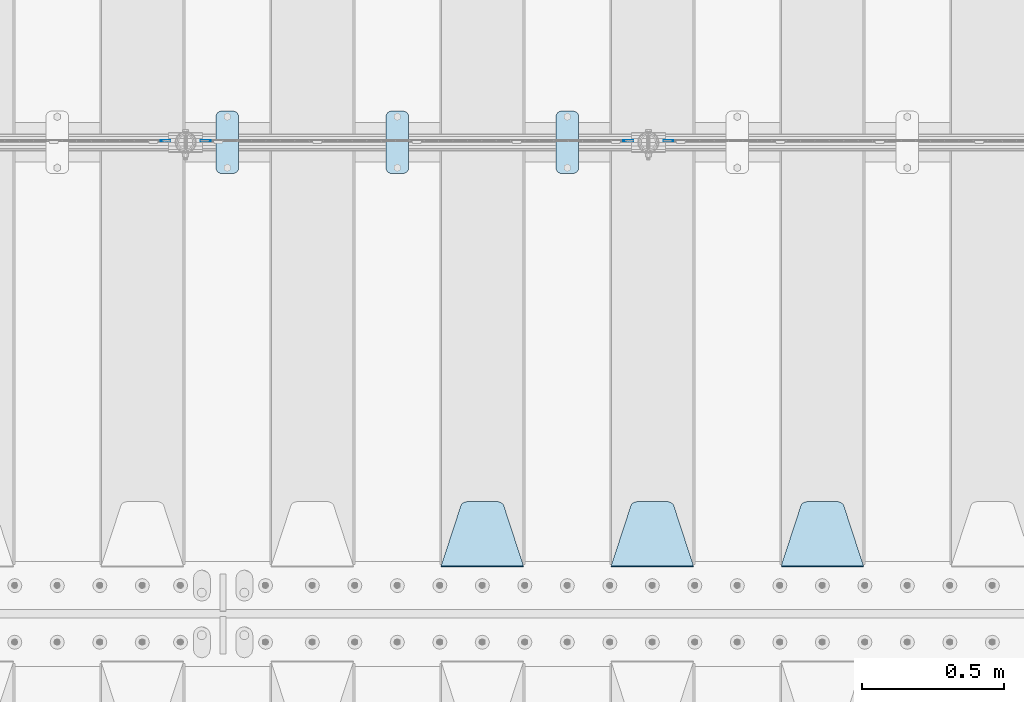
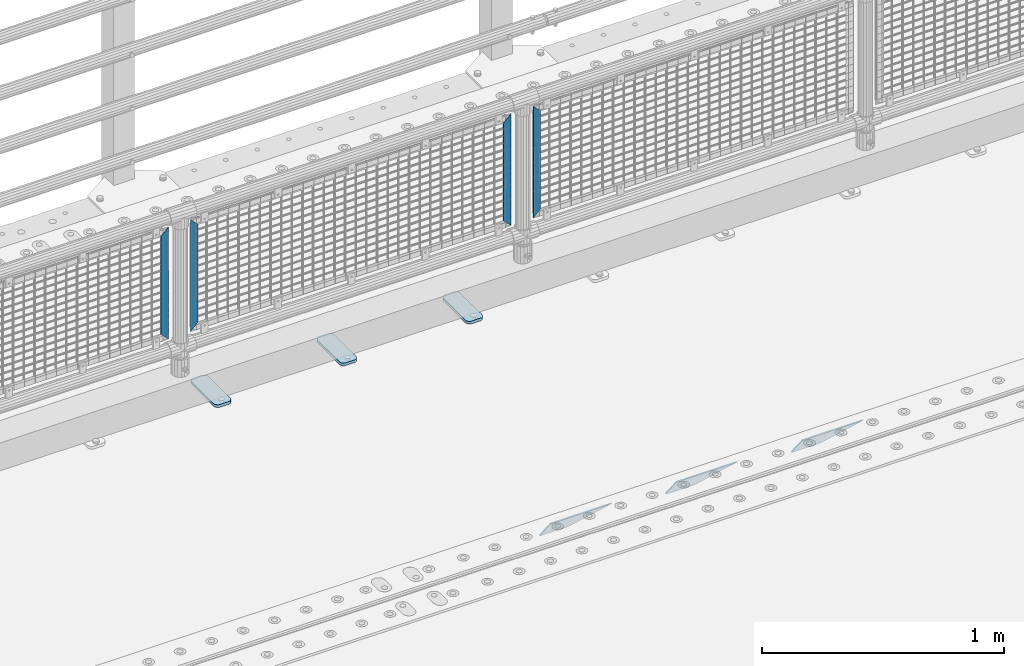
# One storey, part 210 of 242: 10 plates.
"""IFC2X3 building model written with IfcOpenShell, lengths in millimetres."""

from ifc_helpers import new_model, si_unit, frame, origin_with_axes, place, context, subcontext, project, spatial, faceted_brep, material, type_object, element, save


model = new_model("IFC2X3")

# Units and contexts
model_context = context("Model", 3, precision=1e-05, world=origin_with_axes())
body_context = subcontext(model_context, "Body", "Model", "MODEL_VIEW")
ifc_project = project(units=[si_unit("LENGTHUNIT", "METRE", prefix="MILLI"), si_unit("AREAUNIT", "SQUARE_METRE"), si_unit("VOLUMEUNIT", "CUBIC_METRE"), si_unit("MASSUNIT", "GRAM", prefix="KILO"), si_unit("TIMEUNIT", "SECOND"), si_unit("PLANEANGLEUNIT", "RADIAN"), si_unit("SOLIDANGLEUNIT", "STERADIAN"), si_unit("THERMODYNAMICTEMPERATUREUNIT", "DEGREE_CELSIUS"), si_unit("LUMINOUSINTENSITYUNIT", "LUMEN")], contexts=[model_context])

# Site, building, storey
site_placement = place(None, origin_with_axes())
site = spatial("IfcSite", under=ifc_project, at=site_placement, CompositionType="ELEMENT")
building_placement = place(site_placement, origin_with_axes())
building = spatial("IfcBuilding", under=site, at=building_placement, Name="Standard", CompositionType="ELEMENT")
storey_placement = place(building_placement, origin_with_axes())
storey = spatial("IfcBuildingStorey", under=building, at=storey_placement, Name="Undefined", CompositionType="ELEMENT", Elevation=0.0)

# Plates
ifc_material_1 = material(Name="Misc_Undefined")
plate_type_1 = type_object("IfcPlateType", PredefinedType="NOTDEFINED")
for number, where, z_axis, x_axis in (
    (1, (-33575.490286459, -19329.5, 879.519963133601), (-0.707008801899319, 0.0, -0.707204746899291), (-0.707204746899296, 0.0, 0.707008801899313)),
    (2, (-35208.490286459, -19329.5, 879.519963133601), (-0.707008801899319, 0.0, -0.707204746899291), (-0.707204746899296, 0.0, 0.707008801899313)),
):
    element("IfcPlate", number, at=place(storey_placement, frame(where, z_axis=z_axis, x_axis=x_axis)), inside=storey, type_object=plate_type_1, material=ifc_material_1, context=body_context, shape_type="Brep", body=[
        faceted_brep([(0.0, -1.50000000000364, 0.0), (-348.552185058597, -1.5, 348.655029296875), (-348.552185058597, 1.5, 348.655029296875), (-3.63797880709171e-12, 1.49999999999636, 0.0), (-348.544891357426, -1.5, 398.152496337891), (-348.544891357426, 1.5, 398.152496337891), (49.5043945312464, -1.5, 8.00355337560177e-11), (49.5043945312464, 1.5, 8.00355337560177e-11)], [[[0, 1, 2, 3]], [[1, 4, 5, 2]], [[4, 6, 7, 5]], [[6, 0, 3, 7]], [[5, 7, 3, 2]], [[6, 4, 1, 0]]]),
    ])
for number, where, z_axis, x_axis in (
    (3, (-33752.5003125164, -19329.5, 879.52), (0.707103624179499, 0.0, -0.707109938179501), (0.707109938179508, 0.0, 0.707103624179492)),
    (4, (-35385.5003125164, -19329.5, 879.52), (0.707103624179499, 0.0, -0.707109938179501), (0.707109938179508, 0.0, 0.707103624179492)),
):
    element("IfcPlate", number, at=place(storey_placement, frame(where, z_axis=z_axis, x_axis=x_axis)), inside=storey, type_object=plate_type_1, material=ifc_material_1, context=body_context, shape_type="Brep", body=[
        faceted_brep([(0.0, -1.50000000000364, 0.0), (-348.605163574222, -1.5, 348.602081298832), (-348.605163574222, 1.5, 348.602081298832), (-3.63797880709171e-12, 1.49999999999636, 0.0), (-348.605163574222, -1.5, 398.099334716801), (-348.605163574222, 1.5, 398.099334716801), (49.4976959228534, -1.5, -3.63797880709171e-12), (49.4976959228534, 1.5, -3.63797880709171e-12)], [[[0, 1, 2, 3]], [[1, 4, 5, 2]], [[4, 6, 7, 5]], [[6, 0, 3, 7]], [[5, 7, 3, 2]], [[6, 4, 1, 0]]]),
    ])
ifc_material_2 = material(Name="STEEL/S355J2")
plate_type_2 = type_object("IfcPlateType", PredefinedType="NOTDEFINED")
plate_1_placement = place(storey_placement, frame((-33990.0, -19225.5, 21.0199999999977), z_axis=(1.0, 0.0, 0.0), x_axis=(0.0, -1.0, 0.0)))
element("IfcPlate", 5, at=plate_1_placement, inside=storey, type_object=plate_type_2, material=ifc_material_2, context=body_context, shape_type="Brep", body=[
    faceted_brep([(0.0, -7.0, 20.0), (0.0, -7.0, 60.0), (0.0, 7.0, 60.0), (0.0, 7.0, 20.0), (0.384294391937146, -7.0, 63.9018064403208), (0.384294391937146, 7.0, 63.9018064403208), (1.52240934977453, -7.0, 67.6536686473009), (1.52240934977453, 7.0, 67.6536686473009), (3.37060775395003, -7.0, 71.1114046603907), (3.37060775395003, 7.0, 71.1114046603907), (5.8578643762703, -7.0, 74.1421356237297), (5.8578643762703, 7.0, 74.1421356237297), (8.88859533960931, -7.0, 76.62939224605), (8.88859533960931, 7.0, 76.62939224605), (12.3463313526991, -7.0, 78.4775906502255), (12.3463313526991, 7.0, 78.4775906502255), (16.0981935596792, -7.0, 79.6157056080629), (16.0981935596792, 7.0, 79.6157056080629), (20.0, -7.0, 80.0), (20.0, 7.0, 80.0), (200.0, -7.0, 80.0), (200.0, 7.0, 80.0), (203.901806440321, -7.0, 79.6157056080629), (203.901806440321, 7.0, 79.6157056080629), (207.653668647301, -7.0, 78.4775906502255), (207.653668647301, 7.0, 78.4775906502255), (211.111404660391, -7.0, 76.62939224605), (211.111404660391, 7.0, 76.62939224605), (214.14213562373, -7.0, 74.1421356237297), (214.14213562373, 7.0, 74.1421356237297), (216.62939224605, -7.0, 71.1114046603907), (216.62939224605, 7.0, 71.1114046603907), (218.477590650225, -7.0, 67.6536686473009), (218.477590650225, 7.0, 67.6536686473009), (219.615705608063, -7.0, 63.9018064403208), (219.615705608063, 7.0, 63.9018064403208), (220.0, -7.0, 60.0), (220.0, 7.0, 60.0), (220.0, -7.0, 20.0), (220.0, 7.0, 20.0), (219.615705608063, -7.0, 16.0981935596792), (219.615705608063, 7.0, 16.0981935596792), (218.477590650225, -7.0, 12.3463313526991), (218.477590650225, 7.0, 12.3463313526991), (216.62939224605, -7.0, 8.88859533960931), (216.62939224605, 7.0, 8.88859533960931), (214.14213562373, -7.0, 5.8578643762703), (214.14213562373, 7.0, 5.8578643762703), (211.111404660391, -7.0, 3.37060775395003), (211.111404660391, 7.0, 3.37060775395003), (207.653668647301, -7.0, 1.52240934977453), (207.653668647301, 7.0, 1.52240934977453), (203.901806440321, -7.0, 0.384294391937146), (203.901806440321, 7.0, 0.384294391937146), (200.0, -7.0, 0.0), (200.0, 7.0, 0.0), (20.0, -7.0, 0.0), (20.0, 7.0, 0.0), (16.0981935596792, -7.0, 0.384294391937146), (16.0981935596792, 7.0, 0.384294391937146), (12.3463313526991, -7.0, 1.52240934977453), (12.3463313526991, 7.0, 1.52240934977453), (8.88859533960931, -7.0, 3.37060775395003), (8.88859533960931, 7.0, 3.37060775395003), (5.8578643762703, -7.0, 5.8578643762703), (5.8578643762703, 7.0, 5.8578643762703), (3.37060775395003, -7.0, 8.88859533960931), (3.37060775395003, 7.0, 8.88859533960931), (1.52240934977453, -7.0, 12.3463313526991), (1.52240934977453, 7.0, 12.3463313526991), (0.384294391937146, -7.0, 16.0981935596792), (0.384294391937146, 7.0, 16.0981935596792)], [[[0, 1, 2, 3]], [[1, 4, 5, 2]], [[4, 6, 7, 5]], [[6, 8, 9, 7]], [[8, 10, 11, 9]], [[10, 12, 13, 11]], [[12, 14, 15, 13]], [[14, 16, 17, 15]], [[16, 18, 19, 17]], [[18, 20, 21, 19]], [[20, 22, 23, 21]], [[22, 24, 25, 23]], [[24, 26, 27, 25]], [[26, 28, 29, 27]], [[28, 30, 31, 29]], [[30, 32, 33, 31]], [[32, 34, 35, 33]], [[34, 36, 37, 35]], [[36, 38, 39, 37]], [[38, 40, 41, 39]], [[40, 42, 43, 41]], [[42, 44, 45, 43]], [[44, 46, 47, 45]], [[46, 48, 49, 47]], [[48, 50, 51, 49]], [[50, 52, 53, 51]], [[52, 54, 55, 53]], [[54, 56, 57, 55]], [[56, 58, 59, 57]], [[58, 60, 61, 59]], [[60, 62, 63, 61]], [[62, 64, 65, 63]], [[64, 66, 67, 65]], [[66, 68, 69, 67]], [[68, 70, 71, 69]], [[70, 0, 3, 71]], [[5, 7, 9, 11, 13, 15, 17, 19, 21, 23, 25, 27, 29, 31, 33, 35, 37, 39, 41, 43, 45, 47, 49, 51, 53, 55, 57, 59, 61, 63, 65, 67, 69, 71, 3, 2]], [[70, 68, 66, 64, 62, 60, 58, 56, 54, 52, 50, 48, 46, 44, 42, 40, 38, 36, 34, 32, 30, 28, 26, 24, 22, 20, 18, 16, 14, 12, 10, 8, 6, 4, 1, 0]]]),
])
plate_2_placement = place(storey_placement, frame((-34590.0, -19225.5, 21.0199999999977), z_axis=(1.0, 0.0, 0.0), x_axis=(0.0, -1.0, 0.0)))
element("IfcPlate", 6, at=plate_2_placement, inside=storey, type_object=plate_type_2, material=ifc_material_2, context=body_context, shape_type="Brep", body=[
    faceted_brep([(0.0, -7.0, 20.0), (0.0, -7.0, 60.0), (0.0, 7.0, 60.0), (0.0, 7.0, 20.0), (0.384294391937146, -7.0, 63.9018064403208), (0.384294391937146, 7.0, 63.9018064403208), (1.52240934977453, -7.0, 67.6536686473009), (1.52240934977453, 7.0, 67.6536686473009), (3.37060775395003, -7.0, 71.1114046603907), (3.37060775395003, 7.0, 71.1114046603907), (5.8578643762703, -7.0, 74.1421356237297), (5.8578643762703, 7.0, 74.1421356237297), (8.88859533960931, -7.0, 76.62939224605), (8.88859533960931, 7.0, 76.62939224605), (12.3463313526991, -7.0, 78.4775906502255), (12.3463313526991, 7.0, 78.4775906502255), (16.0981935596792, -7.0, 79.6157056080629), (16.0981935596792, 7.0, 79.6157056080629), (20.0, -7.0, 80.0), (20.0, 7.0, 80.0), (200.0, -7.0, 80.0), (200.0, 7.0, 80.0), (203.901806440321, -7.0, 79.6157056080629), (203.901806440321, 7.0, 79.6157056080629), (207.653668647301, -7.0, 78.4775906502255), (207.653668647301, 7.0, 78.4775906502255), (211.111404660391, -7.0, 76.62939224605), (211.111404660391, 7.0, 76.62939224605), (214.14213562373, -7.0, 74.1421356237297), (214.14213562373, 7.0, 74.1421356237297), (216.62939224605, -7.0, 71.1114046603907), (216.62939224605, 7.0, 71.1114046603907), (218.477590650225, -7.0, 67.6536686473009), (218.477590650225, 7.0, 67.6536686473009), (219.615705608063, -7.0, 63.9018064403208), (219.615705608063, 7.0, 63.9018064403208), (220.0, -7.0, 60.0), (220.0, 7.0, 60.0), (220.0, -7.0, 20.0), (220.0, 7.0, 20.0), (219.615705608063, -7.0, 16.0981935596792), (219.615705608063, 7.0, 16.0981935596792), (218.477590650225, -7.0, 12.3463313526991), (218.477590650225, 7.0, 12.3463313526991), (216.62939224605, -7.0, 8.88859533960931), (216.62939224605, 7.0, 8.88859533960931), (214.14213562373, -7.0, 5.8578643762703), (214.14213562373, 7.0, 5.8578643762703), (211.111404660391, -7.0, 3.37060775395003), (211.111404660391, 7.0, 3.37060775395003), (207.653668647301, -7.0, 1.52240934977453), (207.653668647301, 7.0, 1.52240934977453), (203.901806440321, -7.0, 0.384294391937146), (203.901806440321, 7.0, 0.384294391937146), (200.0, -7.0, 0.0), (200.0, 7.0, 0.0), (20.0, -7.0, 0.0), (20.0, 7.0, 0.0), (16.0981935596792, -7.0, 0.384294391937146), (16.0981935596792, 7.0, 0.384294391937146), (12.3463313526991, -7.0, 1.52240934977453), (12.3463313526991, 7.0, 1.52240934977453), (8.88859533960931, -7.0, 3.37060775395003), (8.88859533960931, 7.0, 3.37060775395003), (5.8578643762703, -7.0, 5.8578643762703), (5.8578643762703, 7.0, 5.8578643762703), (3.37060775395003, -7.0, 8.88859533960931), (3.37060775395003, 7.0, 8.88859533960931), (1.52240934977453, -7.0, 12.3463313526991), (1.52240934977453, 7.0, 12.3463313526991), (0.384294391937146, -7.0, 16.0981935596792), (0.384294391937146, 7.0, 16.0981935596792)], [[[0, 1, 2, 3]], [[1, 4, 5, 2]], [[4, 6, 7, 5]], [[6, 8, 9, 7]], [[8, 10, 11, 9]], [[10, 12, 13, 11]], [[12, 14, 15, 13]], [[14, 16, 17, 15]], [[16, 18, 19, 17]], [[18, 20, 21, 19]], [[20, 22, 23, 21]], [[22, 24, 25, 23]], [[24, 26, 27, 25]], [[26, 28, 29, 27]], [[28, 30, 31, 29]], [[30, 32, 33, 31]], [[32, 34, 35, 33]], [[34, 36, 37, 35]], [[36, 38, 39, 37]], [[38, 40, 41, 39]], [[40, 42, 43, 41]], [[42, 44, 45, 43]], [[44, 46, 47, 45]], [[46, 48, 49, 47]], [[48, 50, 51, 49]], [[50, 52, 53, 51]], [[52, 54, 55, 53]], [[54, 56, 57, 55]], [[56, 58, 59, 57]], [[58, 60, 61, 59]], [[60, 62, 63, 61]], [[62, 64, 65, 63]], [[64, 66, 67, 65]], [[66, 68, 69, 67]], [[68, 70, 71, 69]], [[70, 0, 3, 71]], [[5, 7, 9, 11, 13, 15, 17, 19, 21, 23, 25, 27, 29, 31, 33, 35, 37, 39, 41, 43, 45, 47, 49, 51, 53, 55, 57, 59, 61, 63, 65, 67, 69, 71, 3, 2]], [[70, 68, 66, 64, 62, 60, 58, 56, 54, 52, 50, 48, 46, 44, 42, 40, 38, 36, 34, 32, 30, 28, 26, 24, 22, 20, 18, 16, 14, 12, 10, 8, 6, 4, 1, 0]]]),
])
plate_3_placement = place(storey_placement, frame((-35190.0, -19225.5, 21.0199999999977), z_axis=(1.0, 0.0, 0.0), x_axis=(0.0, -1.0, 0.0)))
element("IfcPlate", 7, at=plate_3_placement, inside=storey, type_object=plate_type_2, material=ifc_material_2, context=body_context, shape_type="Brep", body=[
    faceted_brep([(0.0, -7.0, 20.0), (0.0, -7.0, 60.0), (0.0, 7.0, 60.0), (0.0, 7.0, 20.0), (0.384294391937146, -7.0, 63.9018064403208), (0.384294391937146, 7.0, 63.9018064403208), (1.52240934977453, -7.0, 67.6536686473009), (1.52240934977453, 7.0, 67.6536686473009), (3.37060775395003, -7.0, 71.1114046603907), (3.37060775395003, 7.0, 71.1114046603907), (5.8578643762703, -7.0, 74.1421356237297), (5.8578643762703, 7.0, 74.1421356237297), (8.88859533960931, -7.0, 76.62939224605), (8.88859533960931, 7.0, 76.62939224605), (12.3463313526991, -7.0, 78.4775906502255), (12.3463313526991, 7.0, 78.4775906502255), (16.0981935596792, -7.0, 79.6157056080629), (16.0981935596792, 7.0, 79.6157056080629), (20.0, -7.0, 80.0), (20.0, 7.0, 80.0), (200.0, -7.0, 80.0), (200.0, 7.0, 80.0), (203.901806440321, -7.0, 79.6157056080629), (203.901806440321, 7.0, 79.6157056080629), (207.653668647301, -7.0, 78.4775906502255), (207.653668647301, 7.0, 78.4775906502255), (211.111404660391, -7.0, 76.62939224605), (211.111404660391, 7.0, 76.62939224605), (214.14213562373, -7.0, 74.1421356237297), (214.14213562373, 7.0, 74.1421356237297), (216.62939224605, -7.0, 71.1114046603907), (216.62939224605, 7.0, 71.1114046603907), (218.477590650225, -7.0, 67.6536686473009), (218.477590650225, 7.0, 67.6536686473009), (219.615705608063, -7.0, 63.9018064403208), (219.615705608063, 7.0, 63.9018064403208), (220.0, -7.0, 60.0), (220.0, 7.0, 60.0), (220.0, -7.0, 20.0), (220.0, 7.0, 20.0), (219.615705608063, -7.0, 16.0981935596792), (219.615705608063, 7.0, 16.0981935596792), (218.477590650225, -7.0, 12.3463313526991), (218.477590650225, 7.0, 12.3463313526991), (216.62939224605, -7.0, 8.88859533960931), (216.62939224605, 7.0, 8.88859533960931), (214.14213562373, -7.0, 5.8578643762703), (214.14213562373, 7.0, 5.8578643762703), (211.111404660391, -7.0, 3.37060775395003), (211.111404660391, 7.0, 3.37060775395003), (207.653668647301, -7.0, 1.52240934977453), (207.653668647301, 7.0, 1.52240934977453), (203.901806440321, -7.0, 0.384294391937146), (203.901806440321, 7.0, 0.384294391937146), (200.0, -7.0, 0.0), (200.0, 7.0, 0.0), (20.0, -7.0, 0.0), (20.0, 7.0, 0.0), (16.0981935596792, -7.0, 0.384294391937146), (16.0981935596792, 7.0, 0.384294391937146), (12.3463313526991, -7.0, 1.52240934977453), (12.3463313526991, 7.0, 1.52240934977453), (8.88859533960931, -7.0, 3.37060775395003), (8.88859533960931, 7.0, 3.37060775395003), (5.8578643762703, -7.0, 5.8578643762703), (5.8578643762703, 7.0, 5.8578643762703), (3.37060775395003, -7.0, 8.88859533960931), (3.37060775395003, 7.0, 8.88859533960931), (1.52240934977453, -7.0, 12.3463313526991), (1.52240934977453, 7.0, 12.3463313526991), (0.384294391937146, -7.0, 16.0981935596792), (0.384294391937146, 7.0, 16.0981935596792)], [[[0, 1, 2, 3]], [[1, 4, 5, 2]], [[4, 6, 7, 5]], [[6, 8, 9, 7]], [[8, 10, 11, 9]], [[10, 12, 13, 11]], [[12, 14, 15, 13]], [[14, 16, 17, 15]], [[16, 18, 19, 17]], [[18, 20, 21, 19]], [[20, 22, 23, 21]], [[22, 24, 25, 23]], [[24, 26, 27, 25]], [[26, 28, 29, 27]], [[28, 30, 31, 29]], [[30, 32, 33, 31]], [[32, 34, 35, 33]], [[34, 36, 37, 35]], [[36, 38, 39, 37]], [[38, 40, 41, 39]], [[40, 42, 43, 41]], [[42, 44, 45, 43]], [[44, 46, 47, 45]], [[46, 48, 49, 47]], [[48, 50, 51, 49]], [[50, 52, 53, 51]], [[52, 54, 55, 53]], [[54, 56, 57, 55]], [[56, 58, 59, 57]], [[58, 60, 61, 59]], [[60, 62, 63, 61]], [[62, 64, 65, 63]], [[64, 66, 67, 65]], [[66, 68, 69, 67]], [[68, 70, 71, 69]], [[70, 0, 3, 71]], [[5, 7, 9, 11, 13, 15, 17, 19, 21, 23, 25, 27, 29, 31, 33, 35, 37, 39, 41, 43, 45, 47, 49, 51, 53, 55, 57, 59, 61, 63, 65, 67, 69, 71, 3, 2]], [[70, 68, 66, 64, 62, 60, 58, 56, 54, 52, 50, 48, 46, 44, 42, 40, 38, 36, 34, 32, 30, 28, 26, 24, 22, 20, 18, 16, 14, 12, 10, 8, 6, 4, 1, 0]]]),
])
ifc_material_3 = material(Name="STEEL/S355N")
plate_type_3 = type_object("IfcPlateType", PredefinedType="NOTDEFINED")
plate_4_placement = place(storey_placement, frame((-32905.0, -20831.767766953, -1.76776695296758), z_axis=(0.0, 0.707106781186547, -0.707106781186548), x_axis=(-1.0, 0.0, 0.0)))
element("IfcPlate", 8, at=plate_4_placement, inside=storey, type_object=plate_type_3, material=ifc_material_3, context=body_context, shape_type="Brep", body=[
    faceted_brep([(0.0, -2.5, 0.0), (69.345504679477, -2.50000000000182, 300.171731424829), (69.345504679477, 2.5, 300.171731424829), (0.0, 2.5, 0.0), (70.9274061199576, -2.5, 304.897442415398), (70.9274061199576, 2.5, 304.897442415398), (73.3818627772307, -2.5, 309.234538108525), (73.3818627772307, 2.50000000000182, 309.234538108529), (76.6187032999551, -2.5, 313.023683126101), (76.6187032999551, 2.50000000000182, 313.023683126103), (80.5190132704993, -2.5, 316.12567259537), (80.5190132704993, 2.5, 316.12567259537), (84.9395038596849, -2.5, 318.426546230474), (84.9395038596849, 2.50000000000182, 318.426546230476), (89.7177759439219, -2.49999999999818, 319.841774983273), (89.7177759439219, 2.50000000000182, 319.841774983273), (94.678286292652, -2.5, 320.319366455076), (94.678286292652, 2.5, 320.319366455076), (195.321713707348, -2.5, 320.319366455076), (195.321713707348, 2.5, 320.319366455076), (200.282224056078, -2.5, 319.841774983272), (200.282224056078, 2.50000000000182, 319.841774983273), (205.060496140315, -2.5, 318.426546230474), (205.060496140315, 2.49999999999818, 318.426546230474), (209.480986729501, -2.49999999999818, 316.12567259537), (209.480986729501, 2.5, 316.12567259537), (213.381296700045, -2.5, 313.023683126101), (213.381296700045, 2.49999999999818, 313.023683126101), (216.618137222769, -2.5, 309.234538108525), (216.618137222769, 2.5, 309.234538108523), (219.072593880042, -2.49999999999818, 304.897442415398), (219.072593880042, 2.50000000000182, 304.897442415398), (220.654495320523, -2.50000000000182, 300.171731424829), (220.654495320523, 2.5, 300.171731424829), (290.0, -2.5, 0.0), (290.0, 2.5, -1.81898940354586e-12)], [[[0, 1, 2, 3]], [[1, 4, 5, 2]], [[4, 6, 7, 5]], [[6, 8, 9, 7]], [[8, 10, 11, 9]], [[10, 12, 13, 11]], [[12, 14, 15, 13]], [[14, 16, 17, 15]], [[16, 18, 19, 17]], [[18, 20, 21, 19]], [[20, 22, 23, 21]], [[22, 24, 25, 23]], [[24, 26, 27, 25]], [[26, 28, 29, 27]], [[28, 30, 31, 29]], [[30, 32, 33, 31]], [[32, 34, 35, 33]], [[34, 0, 3, 35]], [[5, 7, 9, 11, 13, 15, 17, 19, 21, 23, 25, 27, 29, 31, 33, 35, 3, 2]], [[34, 32, 30, 28, 26, 24, 22, 20, 18, 16, 14, 12, 10, 8, 6, 4, 1, 0]]]),
])
plate_5_placement = place(storey_placement, frame((-33505.0, -20831.767766953, -1.76776695296758), z_axis=(0.0, 0.707106781186547, -0.707106781186548), x_axis=(-1.0, 0.0, 0.0)))
element("IfcPlate", 9, at=plate_5_placement, inside=storey, type_object=plate_type_3, material=ifc_material_3, context=body_context, shape_type="Brep", body=[
    faceted_brep([(0.0, -2.5, 0.0), (69.345504679477, -2.50000000000182, 300.171731424829), (69.345504679477, 2.5, 300.171731424829), (0.0, 2.5, 0.0), (70.9274061199576, -2.5, 304.897442415398), (70.9274061199576, 2.5, 304.897442415398), (73.3818627772307, -2.5, 309.234538108525), (73.3818627772307, 2.50000000000182, 309.234538108529), (76.6187032999551, -2.5, 313.023683126101), (76.6187032999551, 2.50000000000182, 313.023683126103), (80.5190132704993, -2.5, 316.12567259537), (80.5190132704993, 2.5, 316.12567259537), (84.9395038596849, -2.5, 318.426546230474), (84.9395038596849, 2.50000000000182, 318.426546230476), (89.7177759439219, -2.49999999999818, 319.841774983273), (89.7177759439219, 2.50000000000182, 319.841774983273), (94.678286292652, -2.5, 320.319366455076), (94.678286292652, 2.5, 320.319366455076), (195.321713707348, -2.5, 320.319366455076), (195.321713707348, 2.5, 320.319366455076), (200.282224056078, -2.5, 319.841774983272), (200.282224056078, 2.50000000000182, 319.841774983273), (205.060496140315, -2.5, 318.426546230474), (205.060496140315, 2.49999999999818, 318.426546230474), (209.480986729501, -2.49999999999818, 316.12567259537), (209.480986729501, 2.5, 316.12567259537), (213.381296700045, -2.5, 313.023683126101), (213.381296700045, 2.49999999999818, 313.023683126101), (216.618137222769, -2.5, 309.234538108525), (216.618137222769, 2.5, 309.234538108523), (219.072593880042, -2.49999999999818, 304.897442415398), (219.072593880042, 2.50000000000182, 304.897442415398), (220.654495320523, -2.50000000000182, 300.171731424829), (220.654495320523, 2.5, 300.171731424829), (290.0, -2.5, 0.0), (290.0, 2.5, -1.81898940354586e-12)], [[[0, 1, 2, 3]], [[1, 4, 5, 2]], [[4, 6, 7, 5]], [[6, 8, 9, 7]], [[8, 10, 11, 9]], [[10, 12, 13, 11]], [[12, 14, 15, 13]], [[14, 16, 17, 15]], [[16, 18, 19, 17]], [[18, 20, 21, 19]], [[20, 22, 23, 21]], [[22, 24, 25, 23]], [[24, 26, 27, 25]], [[26, 28, 29, 27]], [[28, 30, 31, 29]], [[30, 32, 33, 31]], [[32, 34, 35, 33]], [[34, 0, 3, 35]], [[5, 7, 9, 11, 13, 15, 17, 19, 21, 23, 25, 27, 29, 31, 33, 35, 3, 2]], [[34, 32, 30, 28, 26, 24, 22, 20, 18, 16, 14, 12, 10, 8, 6, 4, 1, 0]]]),
])
plate_6_placement = place(storey_placement, frame((-34105.0, -20831.767766953, -1.76776695296758), z_axis=(0.0, 0.707106781186547, -0.707106781186548), x_axis=(-1.0, 0.0, 0.0)))
element("IfcPlate", 10, at=plate_6_placement, inside=storey, type_object=plate_type_3, material=ifc_material_3, context=body_context, shape_type="Brep", body=[
    faceted_brep([(0.0, -2.5, 0.0), (69.345504679477, -2.50000000000182, 300.171731424829), (69.345504679477, 2.5, 300.171731424829), (0.0, 2.5, 0.0), (70.9274061199576, -2.5, 304.897442415398), (70.9274061199576, 2.5, 304.897442415398), (73.3818627772307, -2.5, 309.234538108525), (73.3818627772307, 2.50000000000182, 309.234538108529), (76.6187032999551, -2.5, 313.023683126101), (76.6187032999551, 2.50000000000182, 313.023683126103), (80.5190132704993, -2.5, 316.12567259537), (80.5190132704993, 2.5, 316.12567259537), (84.9395038596849, -2.5, 318.426546230474), (84.9395038596849, 2.50000000000182, 318.426546230476), (89.7177759439219, -2.49999999999818, 319.841774983273), (89.7177759439219, 2.50000000000182, 319.841774983273), (94.678286292652, -2.5, 320.319366455076), (94.678286292652, 2.5, 320.319366455076), (195.321713707348, -2.5, 320.319366455076), (195.321713707348, 2.5, 320.319366455076), (200.282224056078, -2.5, 319.841774983272), (200.282224056078, 2.50000000000182, 319.841774983273), (205.060496140315, -2.5, 318.426546230474), (205.060496140315, 2.49999999999818, 318.426546230474), (209.480986729501, -2.49999999999818, 316.12567259537), (209.480986729501, 2.5, 316.12567259537), (213.381296700045, -2.5, 313.023683126101), (213.381296700045, 2.49999999999818, 313.023683126101), (216.618137222769, -2.5, 309.234538108525), (216.618137222769, 2.5, 309.234538108523), (219.072593880042, -2.49999999999818, 304.897442415398), (219.072593880042, 2.50000000000182, 304.897442415398), (220.654495320523, -2.50000000000182, 300.171731424829), (220.654495320523, 2.5, 300.171731424829), (290.0, -2.5, 0.0), (290.0, 2.5, -1.81898940354586e-12)], [[[0, 1, 2, 3]], [[1, 4, 5, 2]], [[4, 6, 7, 5]], [[6, 8, 9, 7]], [[8, 10, 11, 9]], [[10, 12, 13, 11]], [[12, 14, 15, 13]], [[14, 16, 17, 15]], [[16, 18, 19, 17]], [[18, 20, 21, 19]], [[20, 22, 23, 21]], [[22, 24, 25, 23]], [[24, 26, 27, 25]], [[26, 28, 29, 27]], [[28, 30, 31, 29]], [[30, 32, 33, 31]], [[32, 34, 35, 33]], [[34, 0, 3, 35]], [[5, 7, 9, 11, 13, 15, 17, 19, 21, 23, 25, 27, 29, 31, 33, 35, 3, 2]], [[34, 32, 30, 28, 26, 24, 22, 20, 18, 16, 14, 12, 10, 8, 6, 4, 1, 0]]]),
])

save(model, "model.ifc")
